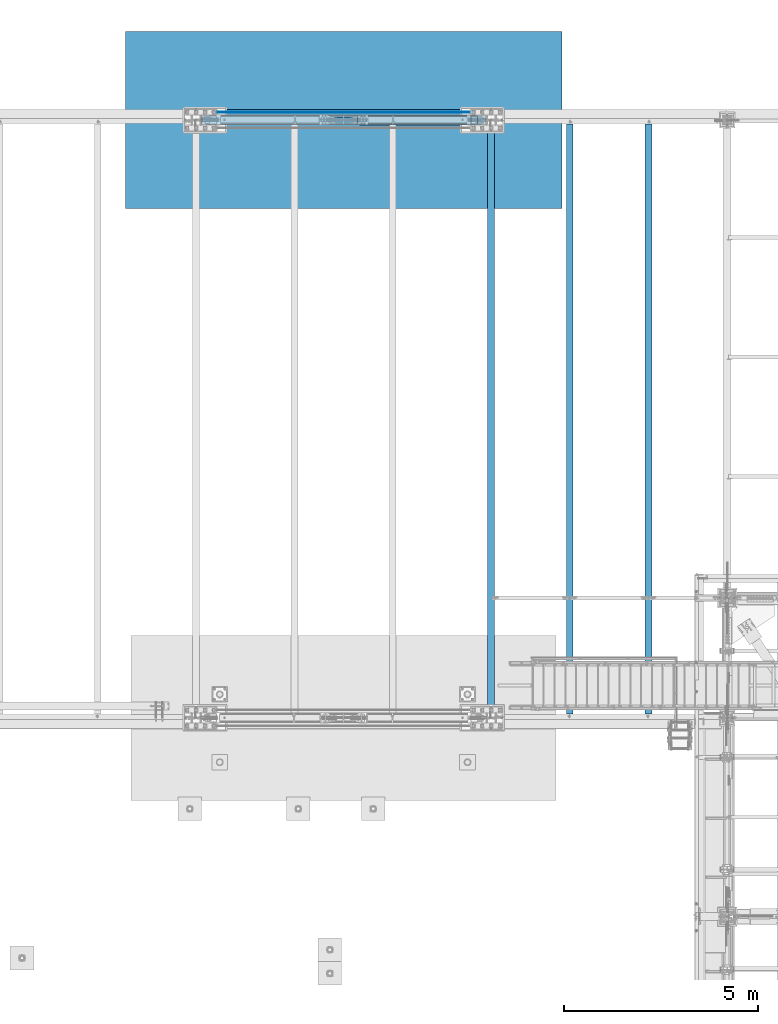
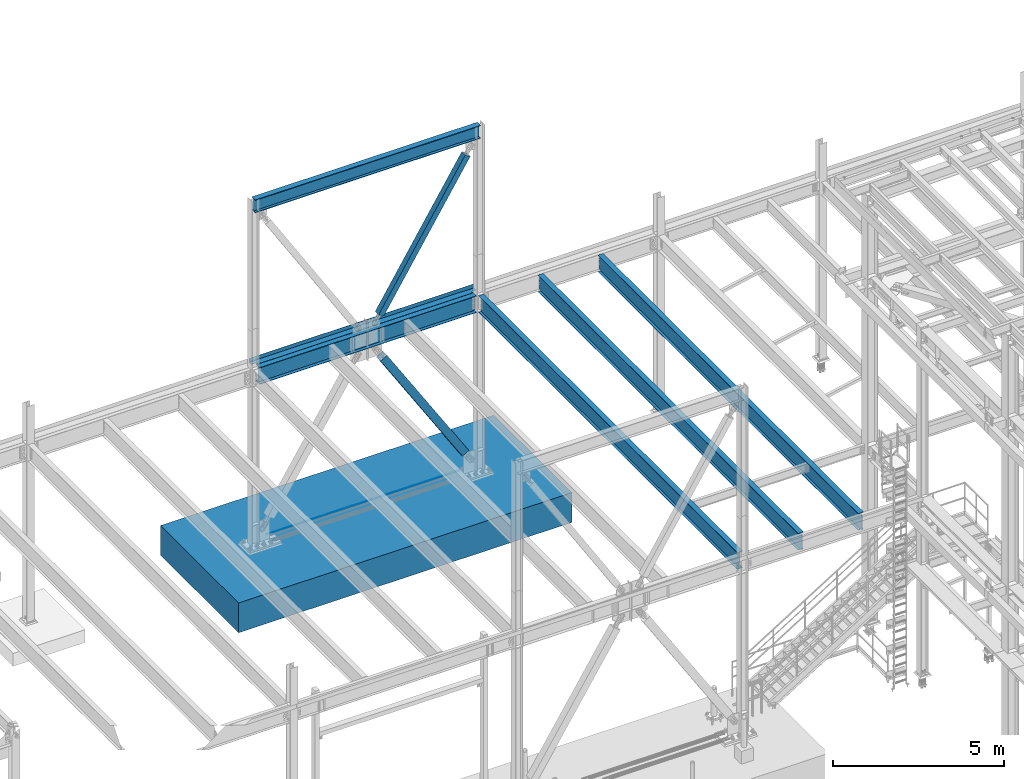
# One storey, part 1933 of 3843: 8 beams, 2 members, 9 elements without a shape of their own.
"""IFC2X3 building model written with IfcOpenShell, lengths in millimetres."""

from ifc_helpers import new_model, si_unit, frame, origin_with_axes, place, context, subcontext, project, spatial, faceted_brep, material, type_object, element, aggregate, save


model = new_model("IFC2X3")

# Units and contexts
model_context = context("Model", 3, precision=1e-05, world=origin_with_axes())
body_context = subcontext(model_context, "Body", "Model", "MODEL_VIEW")
ifc_project = project(units=[si_unit("LENGTHUNIT", "METRE", prefix="MILLI"), si_unit("AREAUNIT", "SQUARE_METRE"), si_unit("VOLUMEUNIT", "CUBIC_METRE"), si_unit("MASSUNIT", "GRAM", prefix="KILO"), si_unit("TIMEUNIT", "SECOND"), si_unit("PLANEANGLEUNIT", "RADIAN"), si_unit("SOLIDANGLEUNIT", "STERADIAN"), si_unit("THERMODYNAMICTEMPERATUREUNIT", "DEGREE_CELSIUS"), si_unit("LUMINOUSINTENSITYUNIT", "LUMEN")], contexts=[model_context])

# Site, building, storey
site_placement = place(None, origin_with_axes())
site = spatial("IfcSite", under=ifc_project, at=site_placement, CompositionType="ELEMENT")
building_placement = place(site_placement, origin_with_axes())
building = spatial("IfcBuilding", under=site, at=building_placement, Name="Undefined", CompositionType="ELEMENT")
storey_placement = place(building_placement, origin_with_axes())
storey = spatial("IfcBuildingStorey", under=building, at=storey_placement, Name="Undefined", CompositionType="ELEMENT", Elevation=0.0)

# Assembly, beam
assembly_1_placement = place(storey_placement, origin_with_axes())
assembly_1 = element("IfcElementAssembly", 1, at=assembly_1_placement, inside=storey, Name="REBAR", AssemblyPlace="NOTDEFINED", PredefinedType="RIGID_FRAME")
ifc_material_1 = material(Name="STEEL/A706-60")
beam_type_1 = type_object("IfcBeamType", Name="#10 REBAR", PredefinedType="NOTDEFINED")
beam_1_placement = place(assembly_1_placement, frame((23418.7999804674, 104762.3, 30132.3375), z_axis=(0.0, 0.0, 1.0), x_axis=(1.0, 0.0, 0.0)))
beam_1 = element("IfcBeam", 2, at=beam_1_placement, type_object=beam_type_1, material=ifc_material_1, Name="REBAR", ObjectType="#10 REBAR", context=body_context, shape_type="Brep", body=[
    faceted_brep([(0.0, -7.9375, 0.0), (0.0, -5.61266007566883, -5.61266007566883), (6502.48749999408, -5.61266007566883, -5.61266007566883), (6502.48749999408, -7.9375, 0.0), (0.0, 0.0, -7.9375), (6502.48749999408, 0.0, -7.9375), (0.0, 5.61266007566883, -5.61266007566883), (6502.48749999408, 5.61266007566883, -5.61266007566883), (0.0, 7.9375, 0.0), (6502.48749999408, 7.9375, 0.0), (0.0, 5.61266007566883, 5.61266007566883), (6502.48749999408, 5.61266007566883, 5.61266007566883), (0.0, 0.0, 7.9375), (6502.48749999408, 0.0, 7.9375), (0.0, -5.61266007566883, 5.61266007566883), (6502.48749999408, -5.61266007566883, 5.61266007566883)], [[[0, 1, 2, 3]], [[1, 4, 5, 2]], [[4, 6, 7, 5]], [[6, 8, 9, 7]], [[8, 10, 11, 9]], [[10, 12, 13, 11]], [[12, 14, 15, 13]], [[14, 0, 3, 15]], [[5, 7, 9, 11, 13, 15, 3, 2]], [[14, 12, 10, 8, 6, 4, 1, 0]]]),
])
aggregate(assembly_1, [beam_1])

# Assembly, member
assembly_2_placement = place(storey_placement, origin_with_axes())
assembly_2 = element("IfcElementAssembly", 3, at=assembly_2_placement, inside=storey, Name="None", AssemblyPlace="NOTDEFINED", PredefinedType="RIGID_FRAME")
ifc_material_2 = material(Name="STEEL/A992")
member_type_1 = type_object("IfcMemberType", Name="HSS8X8X3/16", PredefinedType="NOTDEFINED")
member_1_placement = place(assembly_2_placement, frame((27119.0410490178, 104559.1, 36853.7019844734), z_axis=(0.0, -1.0, 0.0), x_axis=(0.529701321840548, 0.0, 0.848184242744686)))
member_1 = element("IfcMember", 4, at=member_1_placement, type_object=member_type_1, material=ifc_material_2, Name="None", ObjectType="HSS8X8X3/16", context=body_context, shape_type="Brep", body=[
    faceted_brep([(2.03726813197136e-10, 96.8375000003298, -96.8374999999942), (-2.18278728425503e-10, -96.837500000317, -96.8374999999942), (5518.14999998289, -96.8375000060396, -96.8374999999942), (5518.14999998332, 96.8374999946072, -96.8374999999942), (-2.18278728425503e-10, -96.837500000317, 96.8374999999942), (5518.14999998289, -96.8375000060396, 96.8374999999942), (2.03726813197136e-10, 96.8375000003298, 96.8374999999942), (5518.14999998332, 96.8374999946072, 96.8374999999942), (2.18278728425503e-10, 101.600000000345, -101.600000000006), (2.18278728425503e-10, 101.600000000345, 101.600000000006), (5518.14999998333, 101.599999994626, 101.600000000006), (5518.14999998333, 101.599999994626, -101.600000000006), (-2.25554686039686e-10, -101.600000000329, 101.600000000006), (5518.14999998289, -101.600000006059, 101.600000000006), (-2.25554686039686e-10, -101.600000000329, -101.600000000006), (5518.14999998289, -101.600000006059, -101.600000000006)], [[[0, 1, 2, 3]], [[1, 4, 5, 2]], [[4, 6, 7, 5]], [[6, 0, 3, 7]], [[8, 9, 10, 11]], [[9, 12, 13, 10]], [[12, 14, 15, 13]], [[14, 8, 11, 15]], [[13, 15, 11, 10], [5, 7, 3, 2]], [[14, 12, 9, 8], [6, 4, 1, 0]]]),
])
aggregate(assembly_2, [member_1])

# Assembly, beam
assembly_3_placement = place(storey_placement, origin_with_axes())
assembly_3 = element("IfcElementAssembly", 5, at=assembly_3_placement, inside=storey, Name="BEAM", AssemblyPlace="NOTDEFINED", PredefinedType="RIGID_FRAME")
beam_type_2 = type_object("IfcBeamType", Name="W18X65", PredefinedType="NOTDEFINED")
beam_2_placement = place(assembly_3_placement, frame((22860.0, 104559.1, 42235.4375), z_axis=(0.0, 0.0, 1.0), x_axis=(1.0, 0.0, 0.0)))
beam_2 = element("IfcBeam", 6, at=beam_2_placement, type_object=beam_type_2, material=ifc_material_2, Name="BEAM", ObjectType="W18X65", context=body_context, shape_type="Brep", body=[
    faceted_brep([(0.0, 96.8374999999942, -233.362500000003), (0.0, 96.8374999999942, -214.3125), (7620.0, 96.8374999999942, -214.3125), (7620.0, 96.8374999999942, -233.362500000003), (0.0, 5.55624999999418, -214.3125), (7620.0, 5.55624999999418, -214.3125), (0.0, 5.55624999999418, 214.3125), (7620.0, 5.55624999999418, 214.3125), (0.0, 96.8374999999942, 214.3125), (7620.0, 96.8374999999942, 214.3125), (0.0, 96.8374999999942, 233.362500000003), (7620.0, 96.8374999999942, 233.362500000003), (0.0, -96.8374999999942, 233.362500000003), (7620.0, -96.8374999999942, 233.362500000003), (0.0, -96.8374999999942, 214.3125), (7620.0, -96.8374999999942, 214.3125), (0.0, -5.55624999999418, 214.3125), (7620.0, -5.55624999999418, 214.3125), (0.0, -5.55624999999418, -214.3125), (7620.0, -5.55624999999418, -214.3125), (0.0, -96.8374999999942, -214.3125), (7620.0, -96.8374999999942, -214.3125), (0.0, -96.8374999999942, -233.362500000003), (7620.0, -96.8374999999942, -233.362500000003)], [[[0, 1, 2, 3]], [[1, 4, 5, 2]], [[4, 6, 7, 5]], [[6, 8, 9, 7]], [[8, 10, 11, 9]], [[10, 12, 13, 11]], [[12, 14, 15, 13]], [[14, 16, 17, 15]], [[16, 18, 19, 17]], [[18, 20, 21, 19]], [[20, 22, 23, 21]], [[22, 0, 3, 23]], [[5, 7, 9, 11, 13, 15, 17, 19, 21, 23, 3, 2]], [[22, 20, 18, 16, 14, 12, 10, 8, 6, 4, 1, 0]]]),
])
aggregate(assembly_3, [beam_2])

# Assembly, member
assembly_4_placement = place(storey_placement, origin_with_axes())
assembly_4 = element("IfcElementAssembly", 7, at=assembly_4_placement, inside=storey, Name="None", AssemblyPlace="NOTDEFINED", PredefinedType="RIGID_FRAME")
member_type_2 = type_object("IfcMemberType", Name="HSS10X10X1/4", PredefinedType="NOTDEFINED")
member_2_placement = place(assembly_4_placement, frame((29963.229693623, 104559.1, 30939.605175297), z_axis=(0.0, 1.0, 0.0), x_axis=(-0.535402318071675, 0.0, 0.844597157113068)))
member_2 = element("IfcMember", 8, at=member_2_placement, type_object=member_type_2, material=ifc_material_2, Name="None", ObjectType="HSS10X10X1/4", context=body_context, shape_type="Brep", body=[
    faceted_brep([(2.00088834390044e-10, 120.650000000089, -120.649999999994), (-2.03726813197136e-10, -120.650000000081, -120.649999999994), (5175.25000000853, -120.650000001752, -120.649999999994), (5175.25000000861, 120.649999998298, -120.649999999994), (-2.03726813197136e-10, -120.650000000081, 120.649999999994), (5175.25000000853, -120.650000001752, 120.649999999994), (2.00088834390044e-10, 120.650000000089, 120.649999999994), (5175.25000000861, 120.649999998298, 120.649999999994), (2.16459739021957e-10, 127.000000000087, -127.0), (2.16459739021957e-10, 127.000000000087, 127.0), (5175.25000000861, 126.9999999983, 127.0), (5175.25000000861, 126.9999999983, -127.0), (-2.14640749618411e-10, -127.00000000008, 127.0), (5175.25000000852, -127.000000001754, 127.0), (-2.14640749618411e-10, -127.00000000008, -127.0), (5175.25000000852, -127.000000001754, -127.0)], [[[0, 1, 2, 3]], [[1, 4, 5, 2]], [[4, 6, 7, 5]], [[6, 0, 3, 7]], [[8, 9, 10, 11]], [[9, 12, 13, 10]], [[12, 14, 15, 13]], [[14, 8, 11, 15]], [[13, 15, 11, 10], [5, 7, 3, 2]], [[14, 12, 9, 8], [6, 4, 1, 0]]]),
])
aggregate(assembly_4, [member_2])

# Assembly, beams
assembly_5_placement = place(storey_placement, origin_with_axes())
assembly_5 = element("IfcElementAssembly", 9, at=assembly_5_placement, inside=storey, Name="BEAM", AssemblyPlace="NOTDEFINED", PredefinedType="RIGID_FRAME")
ifc_material_3 = material(Name="STEEL/A36")
beam_type_3 = type_object("IfcBeamType", PredefinedType="NOTDEFINED")
beam_3_placement = place(assembly_5_placement, frame((26670.0, 104622.6, 36439.475), z_axis=(-1.0, 0.0, 0.0), x_axis=(0.0, 1.0, 0.0)))
beam_3 = element("IfcBeam", 10, at=beam_3_placement, type_object=beam_type_3, material=ifc_material_3, Name="BENT_PLATE", context=body_context, shape_type="Brep", body=[
    faceted_brep([(57.1494999999268, -3.17499999999563, -19.0499977696745), (57.1494999999268, 3.17500000000291, -19.0499977696745), (0.0, 3.17500000000291, -19.0499999999956), (0.0, -3.17500000000291, -19.0499999999956), (57.1494999999268, -3.17499999999563, 19.050002230324), (57.1494999999268, 3.17500000000291, 19.050002230324), (4.36557456851006e-11, -3.17499999998836, 19.0499992370969), (1.45519152283669e-11, 3.17499999998836, 19.0499992370824), (77.7875061034138, -3.17499999999563, 3635.37500000001), (77.7875061034138, 3.17500000000291, 3635.37500000001), (0.0, 3.17500000000291, 3635.375), (0.0, -3.17500000000291, 3635.375), (77.7875061034138, -3.17499999999563, 3806.825), (77.7875061034138, 3.17500000000291, 3806.825), (209.549993896348, -3.17499999999563, 3806.825), (209.549993896391, -136.524996948363, 3806.825), (215.899993896397, -136.524996948363, 3806.825), (215.899993896353, 3.17500000001019, 3806.825), (215.899993896353, 3.17500000001019, -3806.825), (215.899993896397, -136.524996948363, -3806.825), (209.549993896391, -136.524996948363, -3806.825), (209.549993896348, -3.17499999999563, -3806.825), (77.7874969481345, -3.17499999999563, -3806.825), (77.7874969481345, 3.17500000000291, -3806.825), (77.7874969481491, -3.17499999999563, -3636.96249389547), (77.7874969481491, 3.17500000000291, -3636.96249389547), (0.0, -3.17500000000291, -3636.96249389547), (0.0, 3.17500000000291, -3636.96249389547)], [[[0, 1, 2, 3]], [[4, 5, 1, 0]], [[6, 7, 5, 4]], [[8, 9, 10, 11]], [[12, 13, 9, 8]], [[14, 15, 16, 17, 13, 12]], [[18, 17, 16, 19]], [[15, 20, 19, 16]], [[14, 21, 20, 15]], [[18, 19, 20, 21, 22, 23]], [[24, 25, 23, 22]], [[26, 27, 25, 24]], [[27, 26, 3, 2]], [[10, 9, 13, 17, 18, 23, 25, 27, 2, 1, 5, 7]], [[11, 10, 7, 6]], [[3, 26, 24, 22, 21, 14, 12, 8, 11, 6, 4, 0]]]),
])
beam_type_4 = type_object("IfcBeamType", Name="W24X68", PredefinedType="NOTDEFINED")
beam_4_placement = place(assembly_5_placement, frame((22860.0, 104559.1, 36134.675), z_axis=(0.0, 0.0, 1.0), x_axis=(1.0, 0.0, 0.0)))
beam_4 = element("IfcBeam", 11, at=beam_4_placement, type_object=beam_type_4, material=ifc_material_2, Name="BEAM", ObjectType="W24X68", context=body_context, shape_type="Brep", body=[
    faceted_brep([(146.115804864745, 5.55625000002328, 258.762499999997), (146.115804864745, 5.55624999999418, -258.762499999997), (139.700000000001, -5.55624999999418, -258.762499999997), (139.700000000001, -5.55624999999418, 258.762499999997), (195.152324331713, -5.55624999999418, -258.762499999997), (195.152324331713, 5.55624999999418, -258.762499999997), (200.316860659659, 5.55624999999418, -260.284176418114), (200.316860659659, -5.55624999999418, -260.284176418114), (203.831265028453, 5.55624999999418, -264.363011611735), (203.831265028453, -5.55624999999418, -264.363011611735), (204.572642642106, 5.55624999999418, -269.69576829455), (204.572642642106, -5.55624999999418, -269.69576829455), (202.304114366383, 5.55624999999418, -274.578566064927), (202.304114366383, -5.55624999999418, -274.578566064927), (197.750502483541, 5.55624999999418, -277.451291847967), (197.750502483541, -5.55624999999418, -277.451291847967), (164.281999999999, 5.55624999999418, -286.940499999997), (164.281999999999, -5.55624999999418, -286.940499999997), (148.177810053228, 5.55624999999418, -286.940499999997), (148.177810053228, -5.55624999999418, -286.940499999997), (7472.05137989355, 5.55624999999418, -287.337500000001), (7472.05137989355, 114.300000000003, -287.337500000001), (147.948620106454, 114.300000000003, -287.337500000001), (147.948620106454, 5.55624999999418, -287.337500000001), (7480.3, 114.300000000003, -301.625), (139.699999999997, 114.3, -301.625), (7480.3, -114.300000000003, -301.625), (139.699999999997, -114.3, -301.625), (7472.05137989355, -114.300000000003, -287.337500000001), (147.948620106454, -114.300000000003, -287.337500000001), (147.948620106454, -5.55624999999418, -287.337500000001), (7472.05137989355, -5.55624999999418, -287.337500000001), (7471.82218994677, 5.55624999999418, -286.940499999997), (7471.82218994677, -5.55624999999418, -286.940499999997), (7455.718, 5.55624999999418, -286.940499999997), (7455.718, -5.55624999999418, -286.940499999997), (7422.24949751646, 5.55624999999418, -277.451291847967), (7422.24949751646, -5.55624999999418, -277.451291847967), (7417.69588563362, 5.55624999999418, -274.578566064927), (7417.69588563362, -5.55624999999418, -274.578566064927), (7415.42735735789, 5.55624999999418, -269.69576829455), (7415.42735735789, -5.55624999999418, -269.69576829455), (7416.16873497155, 5.55624999999418, -264.363011611735), (7416.16873497155, -5.55624999999418, -264.363011611735), (7419.68313934034, 5.55624999999418, -260.284176418114), (7419.68313934034, -5.55624999999418, -260.284176418114), (7424.84767566829, 5.55624999999418, -258.762499999997), (7424.84767566829, -5.55624999999418, -258.762499999997), (7473.88419513526, 5.55624999999418, -258.762499999997), (7480.3, -5.55624999999418, -258.762499999997), (7480.3, -5.55624999996508, 258.762499999997), (7473.88419513526, 5.55624999999418, 258.762499999997), (7424.02967566829, 5.55624999999418, 258.762499999997), (7424.02967566829, -5.55624999999418, 258.762499999997), (7418.86513934034, 5.55624999999418, 260.284176418114), (7418.86513934034, -5.55624999999418, 260.284176418114), (7415.35073497154, 5.55624999999418, 264.363011611735), (7415.35073497154, -5.55624999999418, 264.363011611735), (7414.60935735789, 5.55624999999418, 269.69576829455), (7414.60935735789, -5.55624999999418, 269.69576829455), (7416.87788563361, 5.55624999999418, 274.578566064927), (7416.87788563361, -5.55624999999418, 274.578566064927), (7421.43149751646, 5.55624999999418, 277.451291847967), (7421.43149751646, -5.55624999999418, 277.451291847967), (7454.9, 5.55624999999418, 286.940499999997), (7454.9, -5.55624999999418, 286.940499999997), (7480.3, 5.55624999999418, 286.940499999997), (7480.3, -5.55624999999418, 286.940499999997), (7480.3, 5.55624999999418, 287.337500000001), (7480.3, -5.55624999999418, 287.337500000001), (7480.3, -114.300000000003, 287.337500000001), (7480.3, 114.300000000003, 287.337500000001), (7472.05140070513, 114.300000000003, 301.625), (7472.05140070513, -114.300000000003, 301.625), (139.699999999997, 5.55625, 287.337500000001), (139.699999999997, 114.3, 287.337500000001), (147.948599294868, 114.300000000003, 301.625), (147.948599294868, -114.300000000003, 301.625), (139.699999999997, -114.3, 287.337500000001), (139.699999999997, -5.55625, 287.337500000001), (139.700000000001, 5.55624999999418, 286.940499999997), (139.700000000001, -5.55624999999418, 286.940499999997), (165.100000000002, 5.55624999999418, 286.940499999997), (165.100000000002, -5.55624999999418, 286.940499999997), (198.56850248354, 5.55624999999418, 277.451291847967), (198.56850248354, -5.55624999999418, 277.451291847967), (203.122114366386, 5.55624999999418, 274.578566064927), (203.122114366386, -5.55624999999418, 274.578566064927), (205.390642642109, 5.55624999999418, 269.69576829455), (205.390642642109, -5.55624999999418, 269.69576829455), (204.649265028456, 5.55624999999418, 264.363011611735), (204.649265028456, -5.55624999999418, 264.363011611735), (201.134860659662, 5.55624999999418, 260.284176418114), (201.134860659662, -5.55624999999418, 260.284176418114), (195.970324331713, 5.55624999999418, 258.762499999997), (195.970324331713, -5.55624999999418, 258.762499999997)], [[[0, 1, 2, 3]], [[4, 5, 6, 7]], [[7, 6, 8, 9]], [[9, 8, 10, 11]], [[11, 10, 12, 13]], [[13, 12, 14, 15]], [[15, 14, 16, 17]], [[17, 16, 18, 19]], [[20, 21, 22, 23]], [[21, 24, 25, 22]], [[24, 26, 27, 25]], [[26, 28, 29, 27]], [[19, 18, 23, 22, 25, 27, 29, 30]], [[28, 31, 30, 29]], [[26, 24, 21, 20, 32, 33, 31, 28]], [[34, 35, 33, 32]], [[35, 34, 36, 37]], [[37, 36, 38, 39]], [[39, 38, 40, 41]], [[41, 40, 42, 43]], [[43, 42, 44, 45]], [[45, 44, 46, 47]], [[47, 46, 48, 49]], [[50, 49, 48, 51]], [[52, 53, 50, 51]], [[53, 52, 54, 55]], [[55, 54, 56, 57]], [[57, 56, 58, 59]], [[59, 58, 60, 61]], [[61, 60, 62, 63]], [[63, 62, 64, 65]], [[65, 64, 66, 67]], [[67, 66, 68, 69]], [[70, 69, 68, 71, 72, 73]], [[71, 68, 74, 75]], [[72, 71, 75, 76]], [[73, 72, 76, 77]], [[70, 73, 77, 78]], [[69, 70, 78, 79]], [[77, 76, 75, 74, 79, 78]], [[80, 81, 79, 74]], [[82, 83, 81, 80]], [[83, 82, 84, 85]], [[85, 84, 86, 87]], [[87, 86, 88, 89]], [[89, 88, 90, 91]], [[91, 90, 92, 93]], [[93, 92, 94, 95]], [[95, 94, 0, 3]], [[4, 7, 9, 11, 13, 15, 17, 19, 30, 31, 33, 35, 37, 39, 41, 43, 45, 47, 49, 50, 53, 55, 57, 59, 61, 63, 65, 67, 69, 79, 81, 83, 85, 87, 89, 91, 93, 95, 3, 2]], [[5, 4, 2, 1]], [[94, 92, 90, 88, 86, 84, 82, 80, 74, 68, 66, 64, 62, 60, 58, 56, 54, 52, 51, 48, 46, 44, 42, 40, 38, 36, 34, 32, 20, 23, 18, 16, 14, 12, 10, 8, 6, 5, 1, 0]]]),
])
aggregate(assembly_5, [beam_3, beam_4])

# Assembly, beam
assembly_6_placement = place(storey_placement, origin_with_axes())
assembly_6 = element("IfcElementAssembly", 12, at=assembly_6_placement, inside=storey, Name="BEAM", AssemblyPlace="NOTDEFINED", PredefinedType="RIGID_FRAME")
beam_type_5 = type_object("IfcBeamType", Name="W24X55", PredefinedType="NOTDEFINED")
beam_5_placement = place(assembly_6_placement, frame((34544.0, 89115.9, 36136.2625), z_axis=(0.0, 0.0, 1.0), x_axis=(0.0, 1.0, 0.0)))
beam_5 = element("IfcBeam", 13, at=beam_5_placement, type_object=beam_type_5, material=ifc_material_2, Name="BEAM", ObjectType="W24X55", context=body_context, shape_type="Brep", body=[
    faceted_brep([(17.4624999999942, -4.76249999999709, -274.897500000006), (17.4624999999942, 4.76249999999709, -274.897500000006), (88.9000001907261, 4.76249999999709, -274.897500000006), (88.9000001907261, -4.76249999999709, -274.897500000006), (93.7600797087653, 4.76249999999709, -275.864229922598), (93.7600797087653, -4.76249999999709, -275.864229922598), (97.8802561769262, 4.76249999999709, -278.617243823071), (97.8802561769262, -4.76249999999709, -278.617243823071), (100.633270077407, 4.76249999999709, -282.737420291225), (100.633270077407, -4.76249999999709, -282.737420291225), (101.599999999991, -88.9000000000015, -287.597499809272), (101.599999999991, 88.9000000000015, -287.597499809272), (101.599999999991, 88.9000000000015, -300.037499999999), (101.599999999991, -88.9000000000015, -300.037499809427), (101.548282822405, -88.9000000000015, -287.337500000001), (101.548282822405, -4.76249999999709, -287.337500000001), (101.548282822405, 4.76249999999709, -287.337500000001), (101.548282822405, 88.9000000000015, -287.337500000001), (15341.6, -88.8999999999996, -300.037499999999), (15341.6, 88.8999999999996, -300.037499999999), (15341.6, 88.8999999999996, -287.597499809272), (15341.6, -88.8999999999996, -287.597499809272), (15341.6, 88.8999999999996, 287.337500000001), (15341.6, 4.76250000000073, 287.337500000001), (101.599999999991, 4.76249999999709, 287.337500000001), (101.599999999991, 88.9000000000015, 287.337500000001), (88.9000001907261, -4.76249999999709, 274.377499999995), (88.9000001907261, 4.76249999999709, 274.377499999995), (17.4624999999942, 4.76249999999709, 274.377499999995), (17.4624999999942, -4.76249999999709, 274.377499999995), (93.7600797087653, -4.76249999999709, 275.344229922586), (93.7600797087653, 4.76249999999709, 275.344229922586), (97.8802561769262, -4.76249999999709, 278.09724382306), (97.8802561769262, 4.76249999999709, 278.09724382306), (100.633270077407, -4.76249999999709, 282.217420291214), (100.633270077407, 4.76249999999709, 282.217420291214), (101.599999999991, -4.76249999999709, 287.07749980926), (101.599999999991, 4.76249999999709, 287.07749980926), (15341.6, -88.8999999999996, 300.037499999999), (15341.6, 88.8999999999996, 300.037499999999), (101.599999999991, 88.9000000000015, 300.037499999999), (101.599999999991, -88.9000000000015, 300.037499809427), (15341.6, -88.8999999999996, 287.337500000001), (101.599999999991, -88.9000000000015, 287.337500000001), (15341.6, -4.76250000000073, 287.337500000001), (101.599999999991, -4.76249999999709, 287.337500000001), (15341.6, -4.76250000000073, 287.07749980926), (15341.6, 4.76250000000073, 287.07749980926), (15342.5667299226, -4.76250000000073, 282.217420291214), (15342.5667299226, 4.76250000000073, 282.217420291214), (15345.3197438231, -4.76250000000073, 278.09724382306), (15345.3197438231, 4.76250000000073, 278.09724382306), (15349.4399202912, -4.76250000000073, 275.344229922586), (15349.4399202912, 4.76250000000073, 275.344229922586), (15354.2999998093, -4.76250000000073, 274.377499999995), (15354.2999998093, 4.76250000000073, 274.377499999995), (15425.7375, -4.76250000000073, 274.377499999995), (15425.7375, 4.76250000000073, 274.377499999995), (15425.7375, -4.76250000000073, -274.897500000006), (15425.7375, 4.76250000000073, -274.897500000006), (15354.2999998093, -4.76250000000073, -274.897500000006), (15354.2999998093, 4.76250000000073, -274.897500000006), (15349.4399202912, -4.76250000000073, -275.864229922598), (15349.4399202912, 4.76250000000073, -275.864229922598), (15345.3197438231, -4.76250000000073, -278.617243823071), (15345.3197438231, 4.76250000000073, -278.617243823071), (15342.5667299226, -4.76250000000073, -282.737420291225), (15342.5667299226, 4.76250000000073, -282.737420291225), (15341.6517171776, -4.76250000000073, -287.337500000001), (15341.6517171776, -88.8999999999996, -287.337500000001), (15341.6517171776, 88.8999999999996, -287.337500000001), (15341.6517171776, 4.76250000000073, -287.337500000001)], [[[0, 1, 2, 3]], [[3, 2, 4, 5]], [[5, 4, 6, 7]], [[7, 6, 8, 9]], [[10, 11, 12, 13]], [[14, 15, 9, 8, 16, 17, 11, 10]], [[18, 19, 20, 21]], [[22, 23, 24, 25]], [[26, 27, 28, 29]], [[30, 31, 27, 26]], [[32, 33, 31, 30]], [[34, 35, 33, 32]], [[36, 37, 35, 34]], [[38, 39, 40, 41]], [[42, 38, 41, 43]], [[44, 42, 43, 45]], [[41, 40, 25, 24, 37, 36, 45, 43]], [[39, 22, 25, 40]], [[38, 42, 44, 46, 47, 23, 22, 39]], [[48, 49, 47, 46]], [[50, 51, 49, 48]], [[52, 53, 51, 50]], [[54, 55, 53, 52]], [[56, 57, 55, 54]], [[57, 56, 58, 59]], [[58, 60, 61, 59]], [[62, 63, 61, 60]], [[64, 65, 63, 62]], [[66, 67, 65, 64]], [[68, 69, 21, 20, 70, 71, 67, 66]], [[13, 18, 21, 69, 14, 10]], [[19, 18, 13, 12]], [[70, 20, 19, 12, 11, 17]], [[71, 70, 17, 16]], [[6, 4, 2, 1, 28, 27, 31, 33, 35, 37, 24, 23, 47, 49, 51, 53, 55, 57, 59, 61, 63, 65, 67, 71, 16, 8]], [[29, 28, 1, 0]], [[68, 66, 64, 62, 60, 58, 56, 54, 52, 50, 48, 46, 44, 45, 36, 34, 32, 30, 26, 29, 0, 3, 5, 7, 9, 15]], [[69, 68, 15, 14]]]),
])
aggregate(assembly_6, [beam_5])

assembly_7_placement = place(storey_placement, origin_with_axes())
assembly_7 = element("IfcElementAssembly", 14, at=assembly_7_placement, inside=storey, Name="BEAM", AssemblyPlace="NOTDEFINED", PredefinedType="RIGID_FRAME")
beam_6_placement = place(assembly_7_placement, frame((32512.0, 89115.9, 36136.2625), z_axis=(0.0, 0.0, 1.0), x_axis=(0.0, 1.0, 0.0)))
beam_6 = element("IfcBeam", 15, at=beam_6_placement, type_object=beam_type_5, material=ifc_material_2, Name="BEAM", ObjectType="W24X55", context=body_context, shape_type="Brep", body=[
    faceted_brep([(17.4624999999942, -4.76249999999709, -274.897500000006), (17.4624999999942, 4.76249999999709, -274.897500000006), (88.9000001907261, 4.76249999999709, -274.897500000006), (88.9000001907261, -4.76249999999709, -274.897500000006), (93.7600797087653, 4.76249999999709, -275.864229922598), (93.7600797087653, -4.76249999999709, -275.864229922598), (97.8802561769262, 4.76249999999709, -278.617243823071), (97.8802561769262, -4.76249999999709, -278.617243823071), (100.633270077407, 4.76249999999709, -282.737420291225), (100.633270077407, -4.76249999999709, -282.737420291225), (101.599999999991, -88.9000000000015, -287.597499809272), (101.599999999991, 88.9000000000015, -287.597499809272), (101.599999999991, 88.9000000000015, -300.037499999999), (101.599999999991, -88.9000000000015, -300.037499809427), (101.548282822405, -88.9000000000015, -287.337500000001), (101.548282822405, -4.76249999999709, -287.337500000001), (101.548282822405, 4.76249999999709, -287.337500000001), (101.548282822405, 88.9000000000015, -287.337500000001), (15341.6, -88.8999999999996, -300.037499999999), (15341.6, 88.8999999999996, -300.037499999999), (15341.6, 88.8999999999996, -287.597499809272), (15341.6, -88.8999999999996, -287.597499809272), (15341.6, 88.8999999999996, 287.337500000001), (15341.6, 4.76250000000073, 287.337500000001), (101.599999999991, 4.76249999999709, 287.337500000001), (101.599999999991, 88.9000000000015, 287.337500000001), (88.9000001907261, -4.76249999999709, 274.377499999995), (88.9000001907261, 4.76249999999709, 274.377499999995), (17.4624999999942, 4.76249999999709, 274.377499999995), (17.4624999999942, -4.76249999999709, 274.377499999995), (93.7600797087653, -4.76249999999709, 275.344229922586), (93.7600797087653, 4.76249999999709, 275.344229922586), (97.8802561769262, -4.76249999999709, 278.09724382306), (97.8802561769262, 4.76249999999709, 278.09724382306), (100.633270077407, -4.76249999999709, 282.217420291214), (100.633270077407, 4.76249999999709, 282.217420291214), (101.599999999991, -4.76249999999709, 287.07749980926), (101.599999999991, 4.76249999999709, 287.07749980926), (15341.6, -88.8999999999996, 300.037499999999), (15341.6, 88.8999999999996, 300.037499999999), (101.599999999991, 88.9000000000015, 300.037499999999), (101.599999999991, -88.9000000000015, 300.037499809427), (15341.6, -88.8999999999996, 287.337500000001), (101.599999999991, -88.9000000000015, 287.337500000001), (15341.6, -4.76250000000073, 287.337500000001), (101.599999999991, -4.76249999999709, 287.337500000001), (15341.6, -4.76250000000073, 287.07749980926), (15341.6, 4.76250000000073, 287.07749980926), (15342.5667299226, -4.76250000000073, 282.217420291214), (15342.5667299226, 4.76250000000073, 282.217420291214), (15345.3197438231, -4.76250000000073, 278.09724382306), (15345.3197438231, 4.76250000000073, 278.09724382306), (15349.4399202912, -4.76250000000073, 275.344229922586), (15349.4399202912, 4.76250000000073, 275.344229922586), (15354.2999998093, -4.76250000000073, 274.377499999995), (15354.2999998093, 4.76250000000073, 274.377499999995), (15425.7375, -4.76250000000073, 274.377499999995), (15425.7375, 4.76250000000073, 274.377499999995), (15425.7375, -4.76250000000073, -274.897500000006), (15425.7375, 4.76250000000073, -274.897500000006), (15354.2999998093, -4.76250000000073, -274.897500000006), (15354.2999998093, 4.76250000000073, -274.897500000006), (15349.4399202912, -4.76250000000073, -275.864229922598), (15349.4399202912, 4.76250000000073, -275.864229922598), (15345.3197438231, -4.76250000000073, -278.617243823071), (15345.3197438231, 4.76250000000073, -278.617243823071), (15342.5667299226, -4.76250000000073, -282.737420291225), (15342.5667299226, 4.76250000000073, -282.737420291225), (15341.6517171776, -4.76250000000073, -287.337500000001), (15341.6517171776, -88.8999999999996, -287.337500000001), (15341.6517171776, 88.8999999999996, -287.337500000001), (15341.6517171776, 4.76250000000073, -287.337500000001)], [[[0, 1, 2, 3]], [[3, 2, 4, 5]], [[5, 4, 6, 7]], [[7, 6, 8, 9]], [[10, 11, 12, 13]], [[14, 15, 9, 8, 16, 17, 11, 10]], [[18, 19, 20, 21]], [[22, 23, 24, 25]], [[26, 27, 28, 29]], [[30, 31, 27, 26]], [[32, 33, 31, 30]], [[34, 35, 33, 32]], [[36, 37, 35, 34]], [[38, 39, 40, 41]], [[42, 38, 41, 43]], [[44, 42, 43, 45]], [[41, 40, 25, 24, 37, 36, 45, 43]], [[39, 22, 25, 40]], [[38, 42, 44, 46, 47, 23, 22, 39]], [[48, 49, 47, 46]], [[50, 51, 49, 48]], [[52, 53, 51, 50]], [[54, 55, 53, 52]], [[56, 57, 55, 54]], [[57, 56, 58, 59]], [[58, 60, 61, 59]], [[62, 63, 61, 60]], [[64, 65, 63, 62]], [[66, 67, 65, 64]], [[68, 69, 21, 20, 70, 71, 67, 66]], [[13, 18, 21, 69, 14, 10]], [[19, 18, 13, 12]], [[70, 20, 19, 12, 11, 17]], [[71, 70, 17, 16]], [[6, 4, 2, 1, 28, 27, 31, 33, 35, 37, 24, 23, 47, 49, 51, 53, 55, 57, 59, 61, 63, 65, 67, 71, 16, 8]], [[29, 28, 1, 0]], [[68, 66, 64, 62, 60, 58, 56, 54, 52, 50, 48, 46, 44, 45, 36, 34, 32, 30, 26, 29, 0, 3, 5, 7, 9, 15]], [[69, 68, 15, 14]]]),
])
aggregate(assembly_7, [beam_6])

assembly_8_placement = place(storey_placement, origin_with_axes())
assembly_8 = element("IfcElementAssembly", 16, at=assembly_8_placement, inside=storey, Name="BEAM", AssemblyPlace="NOTDEFINED", PredefinedType="RIGID_FRAME")
beam_7_placement = place(assembly_8_placement, frame((30480.0, 89115.9, 36136.2625), z_axis=(0.0, 0.0, 1.0), x_axis=(0.0, 1.0, 0.0)))
beam_7 = element("IfcBeam", 17, at=beam_7_placement, type_object=beam_type_5, material=ifc_material_2, Name="BEAM", ObjectType="W24X55", context=body_context, shape_type="Brep", body=[
    faceted_brep([(141.287499999991, -88.9000000000015, -300.037499999999), (141.287499999991, 88.9000000000015, -300.037499999999), (15301.9125, 88.9000000000015, -300.037499999999), (15301.9125, -88.9000000000015, -300.037499999999), (141.287499999991, -88.9000000000015, -287.337500000001), (141.287499999991, -4.76250000000073, -287.337500000001), (141.287499999991, -4.76250000000073, 287.337500000001), (141.287499999991, -88.9000000000015, 287.337500000001), (141.287499999991, -88.9000000000015, 300.037499999999), (141.287499999991, 88.9000000000015, 300.037499999999), (141.287499999991, 88.9000000000015, 287.337500000001), (141.287499999991, 4.76250000000073, 287.337500000001), (141.287499999991, 4.76250000000073, 262.677499999998), (141.287499999991, 4.76250000000073, -196.002512207029), (141.287499999991, 4.76250000000073, -287.337500000001), (141.287499999991, 88.9000000000015, -287.337500000001), (15301.9125, -88.9000000000015, -287.337500000001), (15301.9125, -4.76250000000073, -287.337500000001), (15301.9125, -4.76250000000073, 287.337500000001), (15301.9125, -88.9000000000015, 287.337500000001), (15301.9125, -88.9000000000015, 300.037499999999), (15301.9125, 88.9000000000015, 300.037499999999), (15301.9125, 88.9000000000015, 287.337500000001), (15301.9125, 4.76250000000073, 287.337500000001), (15301.9125, 4.76250000000073, 262.677499999998), (15301.9125, 4.76250000000073, -196.002512207029), (15301.9125, 4.76250000000073, -287.337500000001), (15301.9125, 88.9000000000015, -287.337500000001)], [[[0, 1, 2, 3]], [[0, 4, 5, 6, 7, 8, 9, 10, 11, 12, 13, 14, 15, 1]], [[5, 4, 16, 17]], [[6, 5, 17, 18]], [[7, 6, 18, 19]], [[8, 7, 19, 20]], [[9, 8, 20, 21]], [[10, 9, 21, 22]], [[11, 10, 22, 23]], [[14, 13, 12, 11, 23, 24, 25, 26]], [[15, 14, 26, 27]], [[1, 15, 27, 2]], [[26, 25, 24, 23, 22, 21, 20, 19, 18, 17, 16, 3, 2, 27]], [[4, 0, 3, 16]]]),
])
aggregate(assembly_8, [beam_7])

assembly_9_placement = place(storey_placement, origin_with_axes())
assembly_9 = element("IfcElementAssembly", 18, at=assembly_9_placement, inside=storey, Name="BEAM", AssemblyPlace="NOTDEFINED", PredefinedType="REINFORCEMENT_UNIT")
ifc_material_4 = material(Name="CONCRETE/5000")
beam_type_6 = type_object("IfcBeamType", PredefinedType="NOTDEFINED")
beam_8_placement = place(assembly_9_placement, frame((21031.2, 104559.1, 29489.4), z_axis=(0.0, 0.0, 1.0), x_axis=(1.0, 0.0, 0.0)))
beam_8 = element("IfcBeam", 19, at=beam_8_placement, type_object=beam_type_6, material=ifc_material_4, Name="BEAM", context=body_context, shape_type="Brep", body=[
    faceted_brep([(0.0, 2286.0, -533.400000000001), (0.0, 2286.0, 533.400000000001), (11277.6, 2286.0, 533.400000000001), (11277.6, 2286.0, -533.400000000001), (0.0, -2286.0, 533.400000000001), (11277.6, -2286.0, 533.400000000001), (0.0, -2286.0, -533.400000000001), (11277.6, -2286.0, -533.400000000001)], [[[0, 1, 2, 3]], [[1, 4, 5, 2]], [[4, 6, 7, 5]], [[6, 0, 3, 7]], [[5, 7, 3, 2]], [[6, 4, 1, 0]]]),
])
aggregate(assembly_9, [beam_8])

save(model, "model.ifc")
